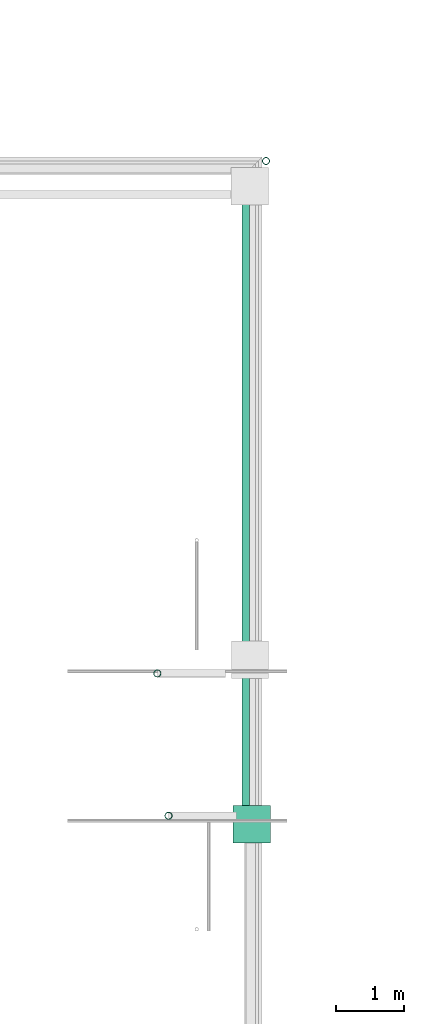
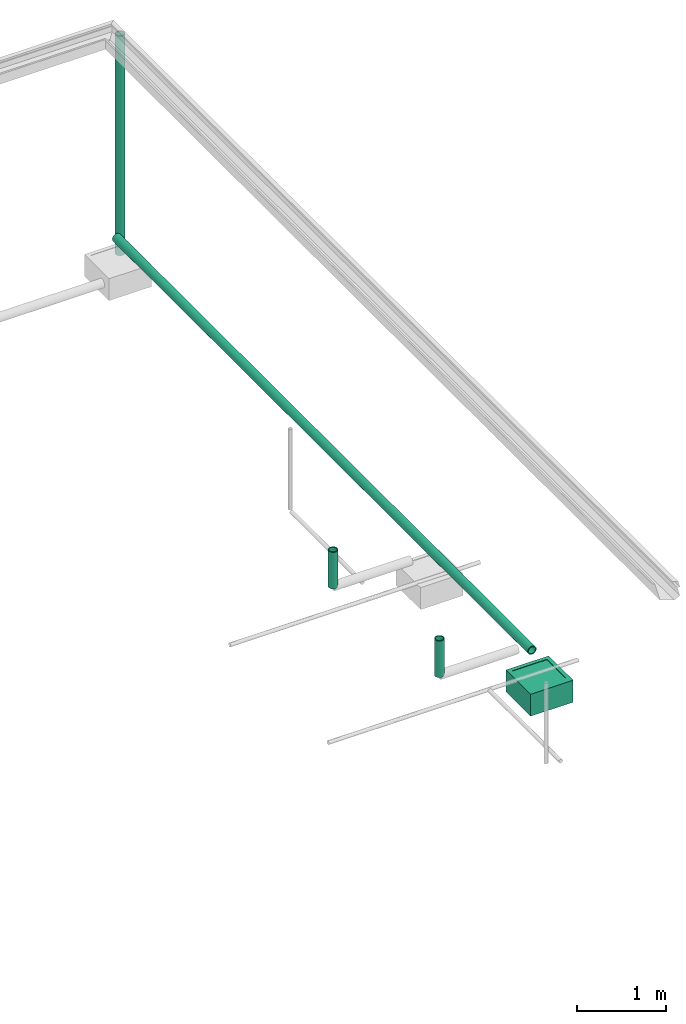
# One storey, part 9 of 15: 4 pipe segments, 1 distribution chamber element.
"""IFC4X3_ADD2 building model written with IfcOpenShell, lengths in metres."""

from ifc_helpers import new_model, entity, si_unit, converted_unit, frame, origin_with_axes, origin_2d_with_axis, place, context, subcontext, project, spatial, hollow_circle, extrude, polygons, source, transform, mapped, material, material_profile, profile_set, profile_usage, type_object, type_shapes, element, save


model = new_model("IFC4X3_ADD2")

# Units and contexts
model_context = context("Model", 3, precision=1e-05, world=origin_with_axes())
plan_context = context("Plan", 2, precision=1e-05, world=origin_2d_with_axis())
body_context = subcontext(model_context, "Body", "Model", "MODEL_VIEW")
ifc_project = project(units=[si_unit("VOLUMEUNIT", "CUBIC_METRE"), si_unit("LENGTHUNIT", "METRE"), converted_unit("PLANEANGLEUNIT", "degree", entity("IfcReal", 0.0174532925199433), si_unit("PLANEANGLEUNIT", "RADIAN"), dimensions=[0, 0, 0, 0, 0, 0, 0]), si_unit("AREAUNIT", "SQUARE_METRE")], contexts=[model_context, plan_context])

# Site, building, storey
site_placement = place(None, origin_with_axes())
site = spatial("IfcSite", under=ifc_project, at=site_placement)
building_placement = place(site_placement, origin_with_axes())
building = spatial("IfcBuilding", under=site, at=building_placement, Name="Building")
storey_placement = place(building_placement, origin_with_axes())
storey = spatial("IfcBuildingStorey", under=building, at=storey_placement, Name="Plumbing")

# Distribution chamber element
distribution_chamber_element_type = type_object("IfcDistributionChamberElementType", Name="1.5ft_WCS", PredefinedType="INSPECTIONCHAMBER")
shared_shape = source(origin_with_axes(), body_context, "Body", "Tessellation", [
    polygons([(0.0499999895691872, 0.0499999895691872, -0.0049999775364995), (0.0499999895691872, 0.0499999895691872, 1.78813941431599e-08), (0.5, 0.0499999895691872, 1.78813941431599e-08), (0.0499999895691872, 0.5, -0.0049999775364995), (0.0499999895691872, 0.5, 1.78813941431599e-08), (0.5, 0.5, -0.0049999775364995), (0.5, 0.5, 1.78813941431599e-08), (0.5, 0.0499999895691872, -0.0049999775364995)], [[[1, 2, 3]], [[4, 5, 2]], [[6, 7, 5]], [[8, 3, 7]], [[8, 6, 4]], [[5, 7, 3]], [[3, 8, 1]], [[2, 1, 4]], [[5, 4, 6]], [[7, 6, 8]], [[4, 1, 8]], [[3, 2, 5]]]),
    polygons([(0.550000011920929, 0.550000011920929, -0.299999982118607), (0.0, 0.550000011920929, 8.94069707157996e-09), (0.0, 0.550000011920929, -0.299999982118607), (0.550000011920929, 0.0, -0.299999982118607), (0.550000011920929, 0.550000011920929, 8.94069707157996e-09), (0.0, 0.0, -0.299999982118607), (0.0, 0.0, 8.94069707157996e-09), (0.550000011920929, 0.0, 8.94069707157996e-09), (0.5, 0.0499999709427357, 8.94069707157996e-09), (0.0499999709427357, 0.0499999709427357, 8.94069707157996e-09), (0.0499999709427357, 0.0499999709427357, -0.00499998638406396), (0.0499999709427357, 0.5, -0.00499998638406396), (0.0499999709427357, 0.5, 8.94069707157996e-09), (0.5, 0.5, -0.00499998638406396), (0.5, 0.5, 8.94069707157996e-09), (0.5, 0.0499999709427357, -0.00499998638406396), (0.493575930595398, 0.0564240589737892, -0.00499998638406396), (0.0564240589737892, 0.0564240589737892, -0.00499998638406396), (0.0564240589737892, 0.493575930595398, -0.19999997317791), (0.0564240589737892, 0.493575930595398, -0.00499998638406396), (0.0564240589737892, 0.0564240589737892, -0.19999997317791), (0.493575930595398, 0.493575930595398, -0.19999997317791), (0.493575930595398, 0.0564240589737892, -0.19999997317791), (0.493575930595398, 0.493575930595398, -0.00499998638406396)], [[[2, 5, 1]], [[1, 3, 2]], [[6, 3, 1]], [[1, 4, 6]], [[4, 1, 5]], [[3, 6, 7]], [[8, 7, 6]], [[6, 4, 8]], [[8, 9, 10]], [[9, 8, 5]], [[5, 8, 4]], [[10, 7, 8]], [[10, 11, 12]], [[11, 10, 9]], [[12, 13, 10]], [[7, 10, 13]], [[13, 12, 14]], [[14, 15, 13]], [[2, 13, 15]], [[13, 2, 7]], [[15, 5, 2]], [[5, 15, 9]], [[15, 14, 16]], [[16, 9, 15]], [[9, 16, 11]], [[16, 17, 18]], [[17, 16, 14]], [[18, 11, 16]], [[18, 21, 19]], [[19, 20, 18]], [[11, 18, 20]], [[21, 18, 17]], [[22, 19, 21]], [[21, 23, 22]], [[17, 23, 21]], [[24, 22, 23]], [[23, 17, 24]], [[12, 20, 24]], [[24, 14, 12]], [[14, 24, 17]], [[22, 24, 20]], [[20, 19, 22]], [[20, 12, 11]], [[7, 2, 3]]]),
])
type_shapes(distribution_chamber_element_type, [shared_shape])
distribution_chamber_element_placement = place(storey_placement, frame((29.1263656616211, 17.3107566833496, 0.029999999329448), z_axis=(0.0, 0.0, 1.0), x_axis=(1.0, 0.0, 0.0)))
element("IfcDistributionChamberElement", 1, at=distribution_chamber_element_placement, inside=storey, type_object=distribution_chamber_element_type, Name="DistributionChamberElement", context=body_context, shape_type="MappedRepresentation", body=[
    mapped(shared_shape, transform((0.0, 0.0, 0.0), x_axis=(1.0, 0.0, 0.0), y_axis=(0.0, 1.0, 0.0), z_axis=(0.0, 0.0, 1.0), scale=1.0)),
])

# Pipe segments
ifc_material = material()
ifc_material_profile_1 = material_profile(ifc_material, hollow_circle(Radius=0.0571499988436699, WallThickness=0.012699999846518))
ifc_profile_set_1 = profile_set([ifc_material_profile_1], Name="rainwater")
ifc_profile_usage_1 = profile_usage(ifc_profile_set_1)
ifc_material_profile_2 = material_profile(ifc_material, hollow_circle(Radius=0.0571499988436699, WallThickness=0.012699999846518))
ifc_profile_set_2 = profile_set([ifc_material_profile_2], Name="rainwater")
pipe_segment_type_1 = type_object("IfcPipeSegmentType", Name="4inch RainWater", PredefinedType="FLEXIBLESEGMENT", material=ifc_profile_set_2)
pipe_segment_1_placement = place(storey_placement, frame((29.6104221343994, 27.3450565338135, -0.189830482006073), z_axis=(4.26004378799822e-14, -1.1920928955078e-07, 0.999999999999993), x_axis=(-0.999999999999924, -3.89414367418765e-07, -3.82137220087854e-15)))
element("IfcPipeSegment", 2, at=pipe_segment_1_placement, inside=storey, type_object=pipe_segment_type_1, material=ifc_profile_usage_1, Name="PipeSegment", PredefinedType="FLEXIBLESEGMENT", context=body_context, shape_type="SweptSolid", body=[
    extrude(hollow_circle(Radius=0.0571499988436699, WallThickness=0.012699999846518), origin_with_axes(), (0.0, 0.0, 1.0), 3.0),
])
ifc_material_profile_3 = material_profile(ifc_material, hollow_circle(Radius=0.0571499988436699, WallThickness=0.012699999846518))
ifc_profile_set_3 = profile_set([ifc_material_profile_3])
ifc_profile_usage_2 = profile_usage(ifc_profile_set_3)
pipe_segment_type_2 = type_object("IfcPipeSegmentType", Name="4inch Tank", PredefinedType="FLEXIBLESEGMENT", material=ifc_profile_set_3)
pipe_segment_2_placement = place(storey_placement, frame((28.1763305664062, 17.7093620300293, 0.387610822916031), z_axis=(-1.19209282445353e-07, -1.19248566576856e-08, 0.999999999999993), x_axis=(7.54979012640431e-08, 0.999999999999997, 1.19248655394699e-08)))
element("IfcPipeSegment", 3, at=pipe_segment_2_placement, inside=storey, type_object=pipe_segment_type_2, material=ifc_profile_usage_2, Name="PipeSegment", PredefinedType="FLEXIBLESEGMENT", context=body_context, shape_type="SweptSolid", body=[
    extrude(hollow_circle(Radius=0.0571499988436699, WallThickness=0.012699999846518), origin_with_axes(), (0.0, 0.0, 1.0), 0.499999970197677),
])
ifc_profile_usage_3 = profile_usage(ifc_profile_set_3)
pipe_segment_3_placement = place(storey_placement, frame((28.0115013122559, 19.8043346405029, 0.387610822916031), z_axis=(-1.19209282445353e-07, -1.19248566576856e-08, 0.999999999999993), x_axis=(7.54979012640431e-08, 0.999999999999997, 1.19248655394699e-08)))
element("IfcPipeSegment", 4, at=pipe_segment_3_placement, inside=storey, type_object=pipe_segment_type_2, material=ifc_profile_usage_3, Name="PipeSegment", PredefinedType="FLEXIBLESEGMENT", context=body_context, shape_type="SweptSolid", body=[
    extrude(hollow_circle(Radius=0.0571499988436699, WallThickness=0.012699999846518), origin_with_axes(), (0.0, 0.0, 1.0), 0.499999970197677),
])
ifc_profile_usage_4 = profile_usage(ifc_profile_set_3)
pipe_segment_4_placement = place(storey_placement, frame((29.3134651184082, 17.6053256988525, 0.387610763311386), z_axis=(3.25841398307584e-07, 0.999999999999944, 7.54979012640391e-08), x_axis=(-0.999999999999871, 3.25841369885851e-07, 3.89414367418744e-07)))
element("IfcPipeSegment", 5, at=pipe_segment_4_placement, inside=storey, type_object=pipe_segment_type_2, material=ifc_profile_usage_4, Name="PipeSegment", PredefinedType="FLEXIBLESEGMENT", context=body_context, shape_type="SweptSolid", body=[
    extrude(hollow_circle(Radius=0.0571499988436699, WallThickness=0.012699999846518), origin_with_axes(), (0.0, 0.0, 1.0), 9.30357926925188),
])

save(model, "model.ifc")
